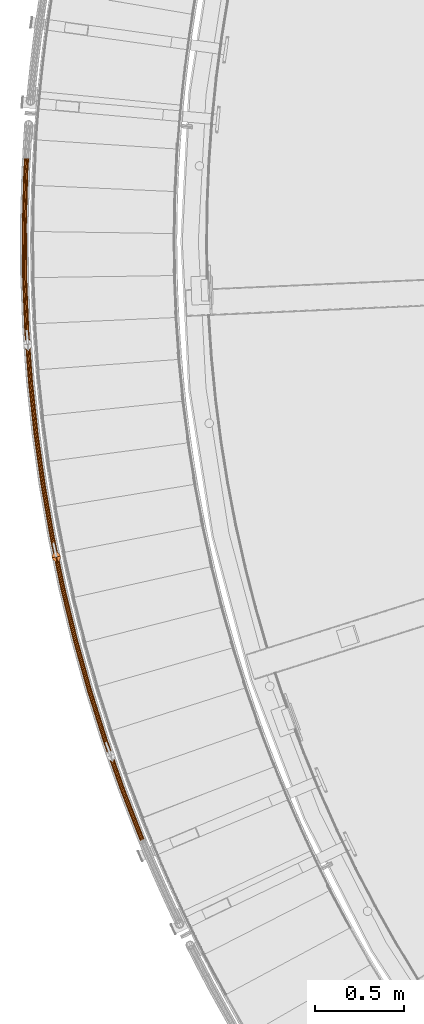
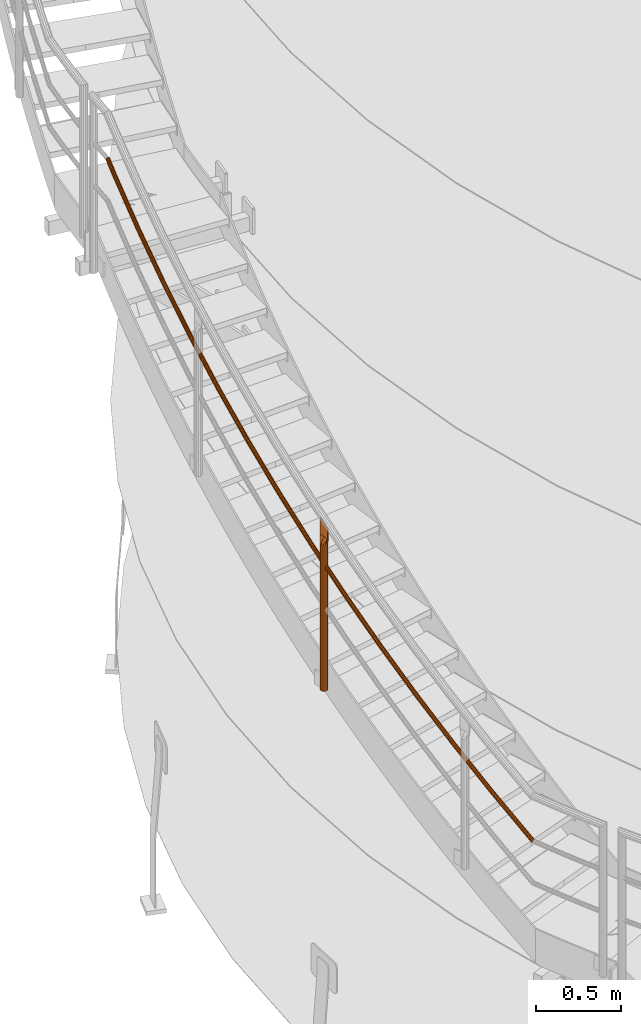
# One storey, part 13 of 126: 2 proxies.
"""IFC2X3 building model written with IfcOpenShell, lengths in millimetres."""

from ifc_helpers import new_model, si_unit, origin, origin_with_axes, place, context, project, spatial, faceted_brep, material, element, save


model = new_model("IFC2X3")

# Units and contexts
context_of_model_1 = context(None, 3, precision=0.1, world=origin())
context_of_model_2 = context(None, 3, precision=0.1, world=origin())
ifc_project = project(units=[si_unit("LENGTHUNIT", "METRE", prefix="MILLI"), si_unit("AREAUNIT", "SQUARE_METRE", prefix="CENTI"), si_unit("VOLUMEUNIT", "CUBIC_METRE", prefix="CENTI"), si_unit("MASSUNIT", "GRAM", prefix="KILO")], contexts=[context_of_model_1, context_of_model_2])

# Site, building, storey
site_placement = place(None, origin_with_axes())
site = spatial("IfcSite", under=ifc_project, at=site_placement, CompositionType="ELEMENT")
building_placement = place(site_placement, origin_with_axes())
building = spatial("IfcBuilding", under=site, at=building_placement, CompositionType="ELEMENT")
storey_placement = place(building_placement, origin_with_axes())
storey = spatial("IfcBuildingStorey", under=building, at=storey_placement, CompositionType="ELEMENT")

# Proxies
ifc_material_1 = material(Name="S235JRG2")
proxy_1_placement = place(storey_placement, origin_with_axes())
element("IfcBuildingElementProxy", 1, at=proxy_1_placement, inside=storey, material=ifc_material_1, context=context_of_model_2, shape_type="Brep", body=[
    faceted_brep([(-195.2856, 4639.9459, 3547.6317), (-201.9048, 4638.318, 3546.2115), (-195.9438, 4624.4189, 3535.5524), (-189.6834, 4626.8834, 3537.6142), (-207.569, 4639.0348, 3542.2264), (-200.9771, 4623.6647, 3530.4392), (-210.7603, 4641.9042, 3536.7441), (-203.4345, 4624.8229, 3523.6446), (-210.6236, 4646.1574, 3531.2336), (-202.6576, 4627.5831, 3516.9892), (-207.1957, 4650.6546, 3527.1715), (-198.8546, 4631.2058, 3512.2564), (-201.3949, 4654.1909, 3525.6461), (-193.0445, 4634.7203, 3510.7143), (-194.7757, 4655.8187, 3527.0662), (-186.7841, 4637.1848, 3512.776), (-189.1116, 4655.1019, 3531.0513), (-181.7508, 4637.939, 3517.8893), (-185.9203, 4652.2325, 3536.5336), (-179.2934, 4636.7808, 3524.6839), (-186.0569, 4647.9794, 3542.0441), (-180.0703, 4634.0206, 3531.3392), (-189.4848, 4643.4822, 3546.1063), (-183.8733, 4630.3979, 3536.072), (-195.7398, 4641.005, 3545.997), (-190.8016, 4644.0154, 3544.6985), (-184.9872, 4630.458, 3534.3014), (-189.9333, 4627.4661, 3535.6142), (-187.8834, 4647.8439, 3541.2404), (-181.7496, 4633.542, 3530.2723), (-187.7671, 4651.4646, 3536.5493), (-181.0883, 4635.8918, 3524.6066), (-190.4839, 4653.9073, 3531.8822), (-183.1803, 4636.8777, 3518.8223), (-195.3057, 4654.5176, 3528.4897), (-187.4651, 4636.2357, 3514.4695), (-200.9407, 4653.1318, 3527.2807), (-192.7946, 4634.1376, 3512.7143), (-205.8789, 4650.1213, 3528.5793), (-197.7407, 4631.1458, 3514.0271), (-208.7971, 4646.2928, 3532.0374), (-200.9783, 4628.0618, 3518.0561), (-208.9134, 4642.6721, 3536.7285), (-201.6396, 4625.712, 3523.7219), (-206.1967, 4640.2294, 3541.3956), (-199.5476, 4624.726, 3529.5061), (-201.3748, 4639.6192, 3544.7881), (-195.2628, 4625.368, 3533.859), (-302.5858, 4914.3219, 3755.2784), (-309.2555, 4912.915, 3753.8583), (-314.8927, 4913.8196, 3749.8731), (-317.9869, 4916.7936, 3744.3908), (-317.7089, 4921.0398, 3738.8803), (-314.1334, 4925.4206, 3734.8182), (-308.2184, 4928.7621, 3733.2928), (-301.5487, 4930.1691, 3734.7129), (-295.9116, 4929.2645, 3738.698), (-292.8173, 4926.2906, 3744.1803), (-293.0952, 4922.0444, 3749.6908), (-296.6707, 4917.6635, 3753.753), (-303.0046, 4915.3955, 3753.6438), (-297.969, 4918.2403, 3752.3452), (-294.9252, 4921.9697, 3748.887), (-294.6887, 4925.5845, 3744.1959), (-297.3228, 4928.1161, 3739.5289), (-302.1217, 4928.8862, 3736.1364), (-307.7996, 4927.6885, 3734.9275), (-312.835, 4924.8438, 3736.226), (-315.8789, 4921.1145, 3739.6841), (-316.1155, 4917.4996, 3744.3752), (-313.4815, 4914.968, 3749.0423), (-308.6825, 4914.1978, 3752.4348), (-400.7085, 5192.1123, 3962.9251), (-407.4213, 5190.9278, 3961.505), (-413.0253, 5192.0193, 3957.5198), (-416.0189, 5195.0944, 3952.0375), (-415.6, 5199.329, 3946.5271), (-411.8808, 5203.5886, 3942.4649), (-405.858, 5206.7317, 3940.9396), (-399.1453, 5207.9162, 3942.3597), (-393.5413, 5206.8248, 3946.3447), (-390.5477, 5203.7498, 3951.827), (-390.9665, 5199.5151, 3957.3375), (-394.6856, 5195.2555, 3961.3997), (-401.0913, 5193.1992, 3961.2905), (-395.964, 5195.875, 3959.992), (-392.7979, 5199.5013, 3956.5338), (-392.4414, 5203.1062, 3951.8427), (-394.9899, 5205.724, 3947.1756), (-399.7606, 5206.6532, 3943.7831), (-405.4752, 5205.6448, 3942.5742), (-410.6024, 5202.969, 3943.8727), (-413.7685, 5199.3429, 3947.3308), (-414.1251, 5195.7379, 3952.0219), (-411.5767, 5193.1201, 3956.689), (-406.806, 5192.1909, 3960.0816), (-489.5452, 5473.0101, 4170.5719), (-496.2937, 5472.0493, 4169.1517), (-501.8584, 5473.3265, 4165.1666), (-504.7481, 5476.4994, 4159.6843), (-504.1887, 5480.7178, 4154.1738), (-500.3301, 5484.8514, 4150.1117), (-494.2061, 5487.7926, 4148.5863), (-487.4578, 5488.7534, 4150.0064), (-481.8931, 5487.4763, 4153.9915), (-479.0033, 5484.3035, 4159.4738), (-479.5626, 5480.0851, 4164.9843), (-483.4212, 5475.9514, 4169.0465), (-489.8918, 5474.1092, 4168.9373), (-484.6784, 5476.6131, 4167.6387), (-481.3935, 5480.1321, 4164.1805), (-480.9174, 5483.7232, 4159.4894), (-483.3775, 5486.4243, 4154.8224), (-488.1147, 5487.5114, 4151.4299), (-493.8596, 5486.6935, 4150.221), (-499.0729, 5484.1896, 4151.5195), (-502.3578, 5480.6707, 4154.9776), (-502.834, 5477.0796, 4159.6686), (-500.3739, 5474.3785, 4164.3357), (-495.6367, 5473.2913, 4167.7283), (-568.998, 5756.7051, 4378.2186), (-575.7746, 5755.9691, 4376.7985), (-581.2938, 5757.4305, 4372.8133), (-584.0765, 5760.6976, 4367.331), (-583.3772, 5764.8951, 4361.8206), (-579.3833, 5768.8982, 4357.7584), (-573.165, 5771.6343, 4356.2331), (-566.3885, 5772.3703, 4357.6532), (-560.8693, 5770.909, 4361.6382), (-558.0865, 5767.6419, 4367.1205), (-558.7857, 5763.4444, 4372.631), (-562.7796, 5759.4412, 4376.6932), (-569.3078, 5757.815, 4376.584), (-564.0141, 5760.1443, 4375.2854), (-560.6141, 5763.5522, 4371.8273), (-560.0189, 5767.1255, 4367.1362), (-562.3879, 5769.9068, 4362.4691), (-567.0863, 5771.1508, 4359.0766), (-572.8552, 5770.5243, 4357.8677), (-578.1488, 5768.195, 4359.1662), (-581.5488, 5764.7872, 4362.6243), (-582.1441, 5761.2139, 4367.3154), (-579.7752, 5758.4326, 4371.9825), (-575.0768, 5757.1885, 4375.3751), (-638.9789, 6042.8837, 4585.8654), (-645.7763, 6042.3734, 4584.4452), (-651.2438, 6044.0173, 4580.4601), (-653.9164, 6047.3752, 4574.9778), (-653.078, 6051.5471, 4569.4673), (-648.9533, 6055.4152, 4565.4052), (-642.6475, 6057.9432, 4563.8798), (-635.8502, 6058.4536, 4565.2999), (-630.3827, 6056.8096, 4569.285), (-627.71, 6053.4519, 4574.7672), (-628.5483, 6049.2799, 4580.2778), (-632.673, 6045.4117, 4584.34), (-639.2516, 6044.0034, 4584.2308), (-633.8834, 6046.1555, 4582.9322), (-630.3721, 6049.4485, 4579.474), (-629.6584, 6053.0001, 4574.7829), (-631.9337, 6055.8585, 4570.1159), (-636.5882, 6057.258, 4566.7234), (-642.3747, 6056.8235, 4565.5144), (-647.7429, 6054.6715, 4566.813), (-651.2542, 6051.3785, 4570.2711), (-651.9679, 6047.827, 4574.9621), (-649.6927, 6044.9684, 4579.6292), (-645.0382, 6043.5689, 4583.0218), (-699.4106, 6331.23, 4793.5121), (-706.2212, 6330.9458, 4792.092), (-711.6311, 6332.7706, 4788.1068), (-714.1906, 6336.2154, 4782.6245), (-713.2141, 6340.3571, 4777.114), (-708.9631, 6344.086, 4773.0519), (-702.5768, 6346.403, 4771.5266), (-695.7663, 6346.6872, 4772.9467), (-690.3564, 6344.8625, 4776.9317), (-687.7968, 6341.4178, 4782.414), (-688.7733, 6337.276, 4787.9245), (-693.0242, 6333.547, 4791.9867), (-699.646, 6332.3581, 4791.8775), (-694.2093, 6334.3306, 4790.5789), (-690.5904, 6337.5051, 4787.1208), (-689.7592, 6341.031, 4782.4297), (-691.9382, 6343.9635, 4777.7626), (-696.5436, 6345.5169, 4774.3701), (-702.3414, 6345.2749, 4773.1612), (-707.7781, 6343.3025, 4774.4597), (-711.3969, 6340.128, 4777.9178), (-712.2283, 6336.6021, 4782.6089), (-710.0493, 6333.6696, 4787.276), (-705.4439, 6332.1161, 4790.6686), (-750.2265, 6621.4253, 5001.1589), (-757.0428, 6621.3676, 4999.7387), (-762.389, 6623.3711, 4995.7536), (-764.8327, 6626.8991, 4990.2713), (-763.719, 6631.0061, 4984.7608), (-759.3465, 6634.5917, 4980.6987), (-752.8867, 6636.6951, 4979.1733), (-746.0705, 6636.7529, 4980.5934), (-740.7243, 6634.7494, 4984.5785), (-738.2805, 6631.2215, 4990.0607), (-739.3941, 6627.1145, 4995.5713), (-743.7666, 6623.5288, 4999.6335), (-750.4243, 6622.5606, 4999.5243), (-744.925, 6624.3513, 4998.2257), (-741.2027, 6627.4038, 4994.7675), (-740.2547, 6630.9001, 4990.0764), (-742.335, 6633.9034, 4985.4094), (-746.8863, 6635.609, 4982.0169), (-752.6889, 6635.5598, 4980.8079), (-758.1881, 6633.7691, 4982.1065), (-761.9105, 6630.7167, 4985.5646), (-762.8585, 6627.2204, 4990.2556), (-760.7783, 6624.2171, 4994.9227), (-756.227, 6622.5114, 4998.3153), (-791.3704, 6913.149, 5208.8056), (-798.1848, 6913.3178, 5207.3855), (-803.4615, 6915.498, 5203.4003), (-805.7866, 6919.1052, 5197.918), (-804.537, 6923.1729, 5192.4075), (-800.0477, 6926.6112, 5188.3454), (-793.5216, 6928.4988, 5186.8201), (-786.7073, 6928.33, 5188.2402), (-781.4306, 6926.15, 5192.2252), (-779.1055, 6922.5428, 5197.7075), (-780.3549, 6918.4751, 5203.218), (-784.8442, 6915.0367, 5207.2802), (-791.5303, 6914.2903, 5207.171), (-785.9746, 6915.8972, 5205.8724), (-782.1528, 6918.8243, 5202.4143), (-781.0892, 6922.2872, 5197.7232), (-783.0686, 6925.358, 5193.0561), (-787.5606, 6927.2139, 5189.6636), (-793.3617, 6927.3576, 5188.4547), (-798.9174, 6925.7507, 5189.7532), (-802.7391, 6922.8236, 5193.2113), (-803.8028, 6919.3607, 5197.9024), (-801.8235, 6916.2899, 5202.5695), (-797.3315, 6914.434, 5205.962), (-822.7968, 7206.0789, 5416.4524), (-829.6018, 7206.4741, 5415.0322), (-834.8032, 7208.8284, 5411.0471), (-837.007, 7212.5109, 5405.5648), (-835.623, 7216.5349, 5400.0543), (-831.0219, 7219.8221, 5395.9922), (-824.4367, 7221.4918, 5394.4668), (-817.6317, 7221.0966, 5395.8869), (-812.4304, 7218.7424, 5399.872), (-810.2264, 7215.06, 5405.3542), (-811.6104, 7211.036, 5410.8647), (-816.2114, 7207.7487, 5414.927), (-822.9187, 7207.2249, 5414.8178), (-817.3126, 7208.6463, 5413.5192), (-813.3957, 7211.4448, 5410.061), (-812.2176, 7214.8704, 5405.3699), (-814.0938, 7218.0053, 5400.7029), (-818.5217, 7220.0094, 5397.3104), (-824.3148, 7220.3458, 5396.1014), (-829.9208, 7218.9244, 5397.4), (-833.8377, 7216.126, 5400.8581), (-835.0159, 7212.7004, 5405.5491), (-833.1397, 7209.5655, 5410.2162), (-828.7119, 7207.5613, 5413.6088), (-844.471, 7499.8914, 5624.0991), (-851.2591, 7500.5126, 5622.679), (-856.3793, 7503.0384, 5618.6938), (-858.4596, 7506.7921, 5613.2115), (-856.9426, 7510.7678, 5607.701), (-852.2349, 7513.9003, 5603.6389), (-845.5978, 7515.3503, 5602.1136), (-838.8097, 7514.7292, 5603.5337), (-833.6895, 7512.2034, 5607.5187), (-831.6091, 7508.4497, 5613.001), (-833.126, 7504.474, 5618.5115), (-837.8338, 7501.3414, 5622.5737), (-844.5547, 7501.0408, 5622.4645), (-838.9045, 7502.2752, 5621.1659), (-834.8968, 7504.9419, 5617.7078), (-833.6054, 7508.3265, 5613.0167), (-835.3765, 7511.522, 5608.3496), (-839.7353, 7513.6722, 5604.9571), (-845.514, 7514.2009, 5603.7482), (-851.1642, 7512.9666, 5605.0467), (-855.1719, 7510.2999, 5608.5048), (-856.4633, 7506.9153, 5613.1959), (-854.6924, 7503.7198, 5617.863), (-850.3335, 7501.5696, 5621.2555), (-856.369, 7794.2619, 5831.7459), (-863.1328, 7795.1083, 5830.3257), (-868.1662, 7797.8029, 5826.3406), (-870.1206, 7801.6237, 5820.8582), (-868.4723, 7805.5468, 5815.3478), (-863.6631, 7808.5211, 5811.2857), (-856.9814, 7809.7497, 5809.7603), (-850.2178, 7808.9033, 5811.1804), (-845.1843, 7806.2088, 5815.1655), (-843.2298, 7802.3881, 5820.6477), (-844.878, 7798.4649, 5826.1582), (-849.6873, 7795.4905, 5830.2205), (-856.4146, 7795.4134, 5830.1113), (-850.7264, 7796.4593, 5828.8127), (-846.6323, 7798.9914, 5825.3545), (-845.2292, 7802.3312, 5820.6634), (-846.893, 7805.5838, 5815.9964), (-851.178, 7807.8777, 5812.6039), (-856.9359, 7808.5982, 5811.3949), (-862.624, 7807.5523, 5812.6935), (-866.7181, 7805.0202, 5816.1516), (-868.1213, 7801.6805, 5820.8426), (-866.4575, 7798.4279, 5825.5097), (-862.1726, 7796.134, 5828.9023), (-858.4778, 8088.8652, 6039.3926), (-865.2097, 8089.9359, 6037.9725), (-870.1508, 8092.7963, 6033.9873), (-871.9772, 8096.6799, 6028.505), (-870.1994, 8100.5461, 6022.9945), (-865.2939, 8103.3589, 6018.9324), (-858.5752, 8104.3648, 6017.4071), (-851.8434, 8103.2941, 6018.8272), (-846.9023, 8100.4338, 6022.8122), (-845.0758, 8096.5503, 6028.2945), (-846.8535, 8092.684, 6033.805), (-851.7589, 8089.8711, 6037.8672), (-858.485, 8090.0176, 6037.758), (-852.7653, 8090.8739, 6036.4594), (-848.5892, 8093.2686, 6033.0013), (-847.0759, 8096.5599, 6028.3102), (-848.6308, 8099.866, 6023.6431), (-852.8371, 8102.3009, 6020.2506), (-858.5679, 8103.2124, 6019.0417), (-864.2876, 8102.3561, 6020.3402), (-868.4637, 8099.9615, 6023.7983), (-869.9771, 8096.6703, 6028.4894), (-868.4223, 8093.3642, 6033.1565), (-864.2159, 8090.9291, 6036.549), (-850.7949, 8383.3759, 6247.0394), (-857.4876, 8384.6697, 6245.6192), (-862.3309, 8387.6927, 6241.6341), (-864.0272, 8391.6349, 6236.1517), (-862.1219, 8395.4399, 6230.6413), (-857.1257, 8398.0881, 6226.5792), (-850.3772, 8398.8701, 6225.0538), (-843.6847, 8397.5763, 6226.4739), (-838.8414, 8394.5534, 6230.459), (-837.145, 8390.6113, 6235.9412), (-839.0501, 8386.8063, 6241.4517), (-844.0464, 8384.1579, 6245.514), (-850.7639, 8384.5279, 6245.4047), (-845.0188, 8385.1936, 6244.1062), (-840.7655, 8387.4482, 6240.648), (-839.1437, 8390.6874, 6235.9569), (-840.5878, 8394.0433, 6231.2898), (-844.7109, 8396.6167, 6227.8974), (-850.4083, 8397.7181, 6226.6884), (-856.1532, 8397.0524, 6227.987), (-860.4065, 8394.7979, 6231.445), (-862.0285, 8391.5588, 6236.1361), (-860.5844, 8388.2028, 6240.8032), (-856.4613, 8385.6293, 6244.1958), (-845.5752, 8471.2669, 6309.0956), (-852.2716, 8472.3285, 6307.4649), (-857.153, 8474.2479, 6302.668), (-858.9127, 8476.5108, 6295.9906), (-857.0797, 8478.5111, 6289.2208), (-852.1448, 8479.7133, 6284.1717), (-845.4291, 8479.795, 6282.1959), (-838.7315, 8478.7342, 6283.8237), (-833.847, 8476.8147, 6288.6201), (-832.0855, 8474.5509, 6295.2999), (-833.9197, 8472.5498, 6302.0725), (-838.8576, 8471.3477, 6307.1221), (-845.5635, 8471.9009, 6307.0956), (-839.845, 8471.9698, 6305.4155), (-835.6415, 8472.9931, 6301.1167), (-834.0801, 8474.6966, 6295.3514), (-835.5795, 8476.6237, 6289.665), (-839.7375, 8478.2578, 6285.5818), (-845.4391, 8479.1609, 6284.1959), (-851.1563, 8479.0914, 6285.8777), (-855.3576, 8478.068, 6290.1761), (-856.9181, 8476.365, 6295.9393), (-855.42, 8474.4386, 6301.624), (-851.2642, 8472.8046, 6305.7075)], [[[0, 1, 2, 3]], [[1, 4, 5, 2]], [[4, 6, 7, 5]], [[6, 8, 9, 7]], [[8, 10, 11, 9]], [[10, 12, 13, 11]], [[12, 14, 15, 13]], [[14, 16, 17, 15]], [[16, 18, 19, 17]], [[18, 20, 21, 19]], [[20, 22, 23, 21]], [[0, 3, 23, 22]], [[24, 25, 26, 27]], [[25, 28, 29, 26]], [[28, 30, 31, 29]], [[30, 32, 33, 31]], [[32, 34, 35, 33]], [[34, 36, 37, 35]], [[36, 38, 39, 37]], [[38, 40, 41, 39]], [[40, 42, 43, 41]], [[42, 44, 45, 43]], [[44, 46, 47, 45]], [[24, 27, 47, 46]], [[0, 48, 49, 1]], [[1, 49, 50, 4]], [[4, 50, 51, 6]], [[6, 51, 52, 8]], [[8, 52, 53, 10]], [[10, 53, 54, 12]], [[12, 54, 55, 14]], [[14, 55, 56, 16]], [[16, 56, 57, 18]], [[18, 57, 58, 20]], [[20, 58, 59, 22]], [[22, 59, 48, 0]], [[24, 60, 61, 25]], [[25, 61, 62, 28]], [[28, 62, 63, 30]], [[30, 63, 64, 32]], [[32, 64, 65, 34]], [[34, 65, 66, 36]], [[36, 66, 67, 38]], [[38, 67, 68, 40]], [[40, 68, 69, 42]], [[42, 69, 70, 44]], [[44, 70, 71, 46]], [[46, 71, 60, 24]], [[48, 72, 73, 49]], [[49, 73, 74, 50]], [[50, 74, 75, 51]], [[51, 75, 76, 52]], [[52, 76, 77, 53]], [[53, 77, 78, 54]], [[54, 78, 79, 55]], [[55, 79, 80, 56]], [[56, 80, 81, 57]], [[57, 81, 82, 58]], [[58, 82, 83, 59]], [[59, 83, 72, 48]], [[60, 84, 85, 61]], [[61, 85, 86, 62]], [[62, 86, 87, 63]], [[63, 87, 88, 64]], [[64, 88, 89, 65]], [[65, 89, 90, 66]], [[66, 90, 91, 67]], [[67, 91, 92, 68]], [[68, 92, 93, 69]], [[69, 93, 94, 70]], [[70, 94, 95, 71]], [[71, 95, 84, 60]], [[72, 96, 97, 73]], [[73, 97, 98, 74]], [[74, 98, 99, 75]], [[75, 99, 100, 76]], [[76, 100, 101, 77]], [[77, 101, 102, 78]], [[78, 102, 103, 79]], [[79, 103, 104, 80]], [[80, 104, 105, 81]], [[81, 105, 106, 82]], [[82, 106, 107, 83]], [[83, 107, 96, 72]], [[84, 108, 109, 85]], [[85, 109, 110, 86]], [[86, 110, 111, 87]], [[87, 111, 112, 88]], [[88, 112, 113, 89]], [[89, 113, 114, 90]], [[90, 114, 115, 91]], [[91, 115, 116, 92]], [[92, 116, 117, 93]], [[93, 117, 118, 94]], [[94, 118, 119, 95]], [[95, 119, 108, 84]], [[96, 120, 121, 97]], [[97, 121, 122, 98]], [[98, 122, 123, 99]], [[99, 123, 124, 100]], [[100, 124, 125, 101]], [[101, 125, 126, 102]], [[102, 126, 127, 103]], [[103, 127, 128, 104]], [[104, 128, 129, 105]], [[105, 129, 130, 106]], [[106, 130, 131, 107]], [[107, 131, 120, 96]], [[108, 132, 133, 109]], [[109, 133, 134, 110]], [[110, 134, 135, 111]], [[111, 135, 136, 112]], [[112, 136, 137, 113]], [[113, 137, 138, 114]], [[114, 138, 139, 115]], [[115, 139, 140, 116]], [[116, 140, 141, 117]], [[117, 141, 142, 118]], [[118, 142, 143, 119]], [[119, 143, 132, 108]], [[120, 144, 145, 121]], [[121, 145, 146, 122]], [[122, 146, 147, 123]], [[123, 147, 148, 124]], [[124, 148, 149, 125]], [[125, 149, 150, 126]], [[126, 150, 151, 127]], [[127, 151, 152, 128]], [[128, 152, 153, 129]], [[129, 153, 154, 130]], [[130, 154, 155, 131]], [[131, 155, 144, 120]], [[132, 156, 157, 133]], [[133, 157, 158, 134]], [[134, 158, 159, 135]], [[135, 159, 160, 136]], [[136, 160, 161, 137]], [[137, 161, 162, 138]], [[138, 162, 163, 139]], [[139, 163, 164, 140]], [[140, 164, 165, 141]], [[141, 165, 166, 142]], [[142, 166, 167, 143]], [[143, 167, 156, 132]], [[144, 168, 169, 145]], [[145, 169, 170, 146]], [[146, 170, 171, 147]], [[147, 171, 172, 148]], [[148, 172, 173, 149]], [[149, 173, 174, 150]], [[150, 174, 175, 151]], [[151, 175, 176, 152]], [[152, 176, 177, 153]], [[153, 177, 178, 154]], [[154, 178, 179, 155]], [[155, 179, 168, 144]], [[156, 180, 181, 157]], [[157, 181, 182, 158]], [[158, 182, 183, 159]], [[159, 183, 184, 160]], [[160, 184, 185, 161]], [[161, 185, 186, 162]], [[162, 186, 187, 163]], [[163, 187, 188, 164]], [[164, 188, 189, 165]], [[165, 189, 190, 166]], [[166, 190, 191, 167]], [[167, 191, 180, 156]], [[168, 192, 193, 169]], [[169, 193, 194, 170]], [[170, 194, 195, 171]], [[171, 195, 196, 172]], [[172, 196, 197, 173]], [[173, 197, 198, 174]], [[174, 198, 199, 175]], [[175, 199, 200, 176]], [[176, 200, 201, 177]], [[177, 201, 202, 178]], [[178, 202, 203, 179]], [[179, 203, 192, 168]], [[180, 204, 205, 181]], [[181, 205, 206, 182]], [[182, 206, 207, 183]], [[183, 207, 208, 184]], [[184, 208, 209, 185]], [[185, 209, 210, 186]], [[186, 210, 211, 187]], [[187, 211, 212, 188]], [[188, 212, 213, 189]], [[189, 213, 214, 190]], [[190, 214, 215, 191]], [[191, 215, 204, 180]], [[192, 216, 217, 193]], [[193, 217, 218, 194]], [[194, 218, 219, 195]], [[195, 219, 220, 196]], [[196, 220, 221, 197]], [[197, 221, 222, 198]], [[198, 222, 223, 199]], [[199, 223, 224, 200]], [[200, 224, 225, 201]], [[201, 225, 226, 202]], [[202, 226, 227, 203]], [[203, 227, 216, 192]], [[204, 228, 229, 205]], [[205, 229, 230, 206]], [[206, 230, 231, 207]], [[207, 231, 232, 208]], [[208, 232, 233, 209]], [[209, 233, 234, 210]], [[210, 234, 235, 211]], [[211, 235, 236, 212]], [[212, 236, 237, 213]], [[213, 237, 238, 214]], [[214, 238, 239, 215]], [[215, 239, 228, 204]], [[216, 240, 241, 217]], [[217, 241, 242, 218]], [[218, 242, 243, 219]], [[219, 243, 244, 220]], [[220, 244, 245, 221]], [[221, 245, 246, 222]], [[222, 246, 247, 223]], [[223, 247, 248, 224]], [[224, 248, 249, 225]], [[225, 249, 250, 226]], [[226, 250, 251, 227]], [[227, 251, 240, 216]], [[228, 252, 253, 229]], [[229, 253, 254, 230]], [[230, 254, 255, 231]], [[231, 255, 256, 232]], [[232, 256, 257, 233]], [[233, 257, 258, 234]], [[234, 258, 259, 235]], [[235, 259, 260, 236]], [[236, 260, 261, 237]], [[237, 261, 262, 238]], [[238, 262, 263, 239]], [[239, 263, 252, 228]], [[240, 264, 265, 241]], [[241, 265, 266, 242]], [[242, 266, 267, 243]], [[243, 267, 268, 244]], [[244, 268, 269, 245]], [[245, 269, 270, 246]], [[246, 270, 271, 247]], [[247, 271, 272, 248]], [[248, 272, 273, 249]], [[249, 273, 274, 250]], [[250, 274, 275, 251]], [[251, 275, 264, 240]], [[252, 276, 277, 253]], [[253, 277, 278, 254]], [[254, 278, 279, 255]], [[255, 279, 280, 256]], [[256, 280, 281, 257]], [[257, 281, 282, 258]], [[258, 282, 283, 259]], [[259, 283, 284, 260]], [[260, 284, 285, 261]], [[261, 285, 286, 262]], [[262, 286, 287, 263]], [[263, 287, 276, 252]], [[264, 288, 289, 265]], [[265, 289, 290, 266]], [[266, 290, 291, 267]], [[267, 291, 292, 268]], [[268, 292, 293, 269]], [[269, 293, 294, 270]], [[270, 294, 295, 271]], [[271, 295, 296, 272]], [[272, 296, 297, 273]], [[273, 297, 298, 274]], [[274, 298, 299, 275]], [[275, 299, 288, 264]], [[276, 300, 301, 277]], [[277, 301, 302, 278]], [[278, 302, 303, 279]], [[279, 303, 304, 280]], [[280, 304, 305, 281]], [[281, 305, 306, 282]], [[282, 306, 307, 283]], [[283, 307, 308, 284]], [[284, 308, 309, 285]], [[285, 309, 310, 286]], [[286, 310, 311, 287]], [[287, 311, 300, 276]], [[288, 312, 313, 289]], [[289, 313, 314, 290]], [[290, 314, 315, 291]], [[291, 315, 316, 292]], [[292, 316, 317, 293]], [[293, 317, 318, 294]], [[294, 318, 319, 295]], [[295, 319, 320, 296]], [[296, 320, 321, 297]], [[297, 321, 322, 298]], [[298, 322, 323, 299]], [[299, 323, 312, 288]], [[300, 324, 325, 301]], [[301, 325, 326, 302]], [[302, 326, 327, 303]], [[303, 327, 328, 304]], [[304, 328, 329, 305]], [[305, 329, 330, 306]], [[306, 330, 331, 307]], [[307, 331, 332, 308]], [[308, 332, 333, 309]], [[309, 333, 334, 310]], [[310, 334, 335, 311]], [[311, 335, 324, 300]], [[312, 336, 337, 313]], [[313, 337, 338, 314]], [[314, 338, 339, 315]], [[315, 339, 340, 316]], [[316, 340, 341, 317]], [[317, 341, 342, 318]], [[318, 342, 343, 319]], [[319, 343, 344, 320]], [[320, 344, 345, 321]], [[321, 345, 346, 322]], [[322, 346, 347, 323]], [[323, 347, 336, 312]], [[324, 348, 349, 325]], [[325, 349, 350, 326]], [[326, 350, 351, 327]], [[327, 351, 352, 328]], [[328, 352, 353, 329]], [[329, 353, 354, 330]], [[330, 354, 355, 331]], [[331, 355, 356, 332]], [[332, 356, 357, 333]], [[333, 357, 358, 334]], [[334, 358, 359, 335]], [[335, 359, 348, 324]], [[336, 360, 361, 337]], [[337, 361, 362, 338]], [[338, 362, 363, 339]], [[339, 363, 364, 340]], [[340, 364, 365, 341]], [[341, 365, 366, 342]], [[342, 366, 367, 343]], [[343, 367, 368, 344]], [[344, 368, 369, 345]], [[345, 369, 370, 346]], [[346, 370, 371, 347]], [[336, 347, 371, 360]], [[348, 372, 373, 349]], [[349, 373, 374, 350]], [[350, 374, 375, 351]], [[351, 375, 376, 352]], [[352, 376, 377, 353]], [[353, 377, 378, 354]], [[354, 378, 379, 355]], [[355, 379, 380, 356]], [[356, 380, 381, 357]], [[357, 381, 382, 358]], [[358, 382, 383, 359]], [[348, 359, 383, 372]], [[7, 9, 11, 13, 15, 17, 19, 21, 23, 3, 2, 5], [26, 29, 31, 33, 35, 37, 39, 41, 43, 45, 47, 27]], [[360, 371, 370, 369, 368, 367, 366, 365, 364, 363, 362, 361], [372, 383, 382, 381, 380, 379, 378, 377, 376, 375, 374, 373]]]),
])
ifc_material_2 = material(Name="1.4462")
proxy_2_placement = place(storey_placement, origin_with_axes())
element("IfcBuildingElementProxy", 2, at=proxy_2_placement, inside=storey, material=ifc_material_2, Name="Pfosten", context=context_of_model_2, shape_type="Brep", body=[
    faceted_brep([(-673.7474, 6208.244, 4851.5008), (-686.2287, 6208.9447, 4851.5008), (-686.2287, 6208.9447, 3807.6446), (-673.7474, 6208.244, 3807.6436), (-696.6874, 6215.7922, 4851.5008), (-696.6874, 6215.7922, 3807.6472), (-702.3213, 6226.9517, 4851.5008), (-702.3213, 6226.9517, 3807.6508), (-701.6205, 6239.433, 4851.5008), (-701.6205, 6239.433, 3807.6545), (-694.773, 6249.8918, 4851.5008), (-694.773, 6249.8918, 3807.6571), (-683.6135, 6255.5256, 4851.5008), (-683.6135, 6255.5256, 3807.6581), (-671.1322, 6254.8248, 4851.5008), (-671.1322, 6254.8248, 3807.6571), (-660.6735, 6247.9773, 4851.5008), (-660.6735, 6247.9773, 3807.6545), (-655.0397, 6236.8179, 4851.5008), (-655.0397, 6236.8179, 3807.6508), (-655.7404, 6224.3365, 4851.5008), (-655.7404, 6224.3365, 3807.6472), (-662.5879, 6213.8778, 4851.5008), (-662.5879, 6213.8778, 3807.6446), (-662.5375, 6246.3114, 4851.5008), (-671.9136, 6252.4501, 4851.5008), (-671.9136, 6252.4501, 3807.6565), (-662.5375, 6246.3114, 3807.6541), (-683.1029, 6253.0783, 4851.5008), (-683.1029, 6253.0783, 3807.6573), (-693.1071, 6248.0277, 4851.5008), (-693.1071, 6248.0277, 3807.6565), (-699.2458, 6238.6516, 4851.5008), (-699.2458, 6238.6516, 3807.6541), (-699.874, 6227.4624, 4851.5008), (-699.874, 6227.4624, 3807.6508), (-694.8234, 6217.4581, 4851.5008), (-694.8234, 6217.4581, 3807.6476), (-685.4473, 6211.3195, 4851.5008), (-685.4473, 6211.3195, 3807.6452), (-674.258, 6210.6913, 4851.5008), (-674.258, 6210.6913, 3807.6443), (-664.2538, 6215.7419, 4851.5008), (-664.2538, 6215.7419, 3807.6452), (-658.1151, 6225.1179, 4851.5008), (-658.1151, 6225.1179, 3807.6476), (-657.487, 6236.3072, 4851.5008), (-657.487, 6236.3072, 3807.6508), (-671.2231, 6196.1468, 4899.8008), (-673.1031, 6196.5025, 4899.8008), (-674.181, 6198.0834, 4899.8008), (-681.1277, 6231.3741, 4899.8008), (-688.0745, 6264.6648, 4899.8008), (-687.7188, 6266.5449, 4899.8008), (-686.1378, 6267.6227, 4899.8008), (-684.2578, 6267.267, 4899.8008), (-683.1799, 6265.6861, 4899.8008), (-676.2332, 6232.3954, 4899.8008), (-669.2865, 6199.1048, 4899.8008), (-669.6422, 6197.2247, 4899.8008), (-685.4314, 6265.2163, 4899.8008), (-685.5176, 6265.3428, 4899.8008), (-685.668, 6265.3712, 4899.8008), (-685.7945, 6265.285, 4899.8008), (-685.8229, 6265.1346, 4899.8008), (-678.8762, 6231.8439, 4899.8008), (-671.9295, 6198.5532, 4899.8008), (-671.8433, 6198.4268, 4899.8008), (-671.6929, 6198.3983, 4899.8008), (-671.5664, 6198.4845, 4899.8008), (-671.538, 6198.6349, 4899.8008), (-678.4847, 6231.9256, 4899.8008), (-671.2231, 6196.1468, 4971.0625), (-673.1031, 6196.5025, 4971.5779), (-674.181, 6198.0834, 4972.8221), (-681.1277, 6231.3741, 4996.7574), (-688.0745, 6264.6648, 5020.6927), (-687.7188, 6266.5449, 5021.9369), (-686.1378, 6267.6227, 5022.4523), (-684.2578, 6267.267, 5021.9369), (-683.1799, 6265.6861, 5020.6927), (-676.2332, 6232.3954, 4996.7574), (-669.2865, 6199.1048, 4972.8221), (-669.6422, 6197.2247, 4971.5779), (-685.4314, 6265.2163, 5020.6927), (-685.5176, 6265.3428, 5020.7922), (-685.668, 6265.3712, 5020.8335), (-685.7945, 6265.285, 5020.7922), (-685.8229, 6265.1346, 5020.6927), (-678.8762, 6231.8439, 4996.7574), (-671.9295, 6198.5532, 4972.8221), (-671.8433, 6198.4268, 4972.7225), (-671.6929, 6198.3983, 4972.6813), (-671.5664, 6198.4845, 4972.7225), (-671.538, 6198.6349, 4972.8221), (-678.4847, 6231.9256, 4996.7574)], [[[0, 1, 2, 3]], [[1, 4, 5, 2]], [[4, 6, 7, 5]], [[6, 8, 9, 7]], [[8, 10, 11, 9]], [[10, 12, 13, 11]], [[12, 14, 15, 13]], [[14, 16, 17, 15]], [[16, 18, 19, 17]], [[18, 20, 21, 19]], [[20, 22, 23, 21]], [[0, 3, 23, 22]], [[24, 25, 26, 27]], [[25, 28, 29, 26]], [[28, 30, 31, 29]], [[30, 32, 33, 31]], [[32, 34, 35, 33]], [[34, 36, 37, 35]], [[36, 38, 39, 37]], [[38, 40, 41, 39]], [[40, 42, 43, 41]], [[42, 44, 45, 43]], [[44, 46, 47, 45]], [[24, 27, 47, 46]], [[0, 48, 49, 1]], [[1, 49, 50, 4]], [[4, 50, 51, 6]], [[6, 51, 52, 8]], [[8, 52, 53, 10]], [[10, 53, 54, 12]], [[12, 54, 55, 14]], [[14, 55, 56, 16]], [[16, 56, 57, 18]], [[18, 57, 58, 20]], [[20, 58, 59, 22]], [[22, 59, 48, 0]], [[24, 60, 61, 25]], [[25, 61, 62, 28]], [[28, 62, 63, 30]], [[30, 63, 64, 32]], [[32, 64, 65, 34]], [[34, 65, 66, 36]], [[36, 66, 67, 38]], [[38, 67, 68, 40]], [[40, 68, 69, 42]], [[42, 69, 70, 44]], [[44, 70, 71, 46]], [[46, 71, 60, 24]], [[48, 72, 73, 49]], [[49, 73, 74, 50]], [[50, 74, 75, 51]], [[51, 75, 76, 52]], [[52, 76, 77, 53]], [[53, 77, 78, 54]], [[54, 78, 79, 55]], [[55, 79, 80, 56]], [[56, 80, 81, 57]], [[57, 81, 82, 58]], [[58, 82, 83, 59]], [[48, 59, 83, 72]], [[60, 84, 85, 61]], [[61, 85, 86, 62]], [[62, 86, 87, 63]], [[63, 87, 88, 64]], [[64, 88, 89, 65]], [[65, 89, 90, 66]], [[66, 90, 91, 67]], [[67, 91, 92, 68]], [[68, 92, 93, 69]], [[69, 93, 94, 70]], [[70, 94, 95, 71]], [[60, 71, 95, 84]], [[7, 9, 11, 13, 15, 17, 19, 21, 23, 3, 2, 5], [26, 29, 31, 33, 35, 37, 39, 41, 43, 45, 47, 27]], [[74, 73, 72, 83, 82, 81, 80, 79, 78, 77, 76, 75], [84, 95, 94, 93, 92, 91, 90, 89, 88, 87, 86, 85]]]),
])

save(model, "model.ifc")
